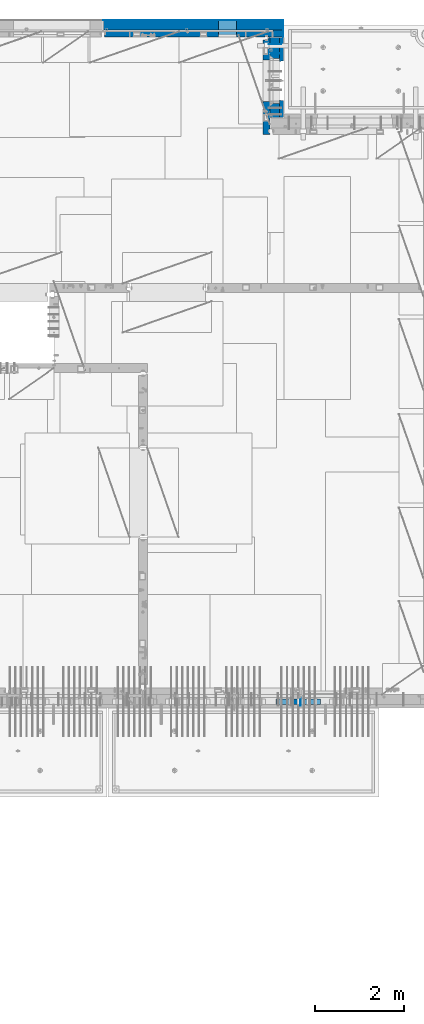
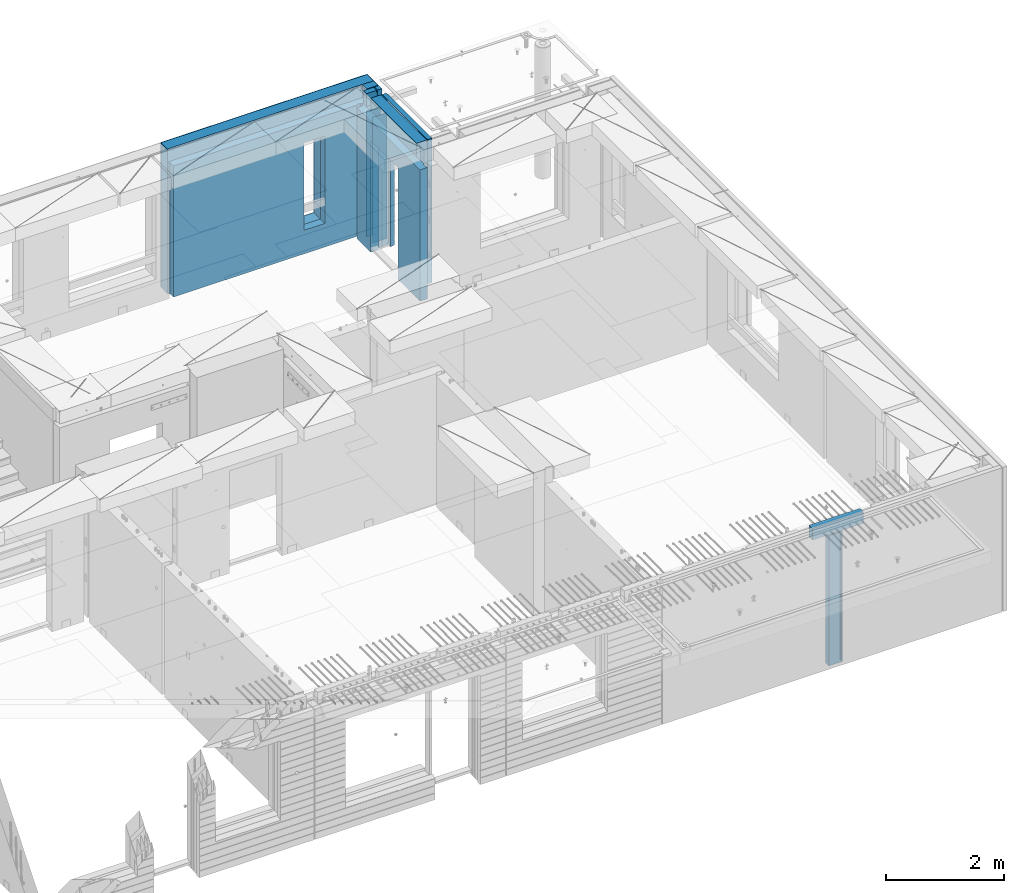
# One storey, part 229 of 334: 13 walls, 5 elements without a shape of their own.
"""IFC2X3 building model written with IfcOpenShell, lengths in millimetres."""

from ifc_helpers import new_model, si_unit, frame, origin_with_axes, place, context, subcontext, project, spatial, faceted_brep, material, type_object, element, aggregate, save


model = new_model("IFC2X3")

# Units and contexts
model_context = context("Model", 3, precision=1e-05, world=origin_with_axes())
body_context = subcontext(model_context, "Body", "Model", "MODEL_VIEW")
ifc_project = project(units=[si_unit("LENGTHUNIT", "METRE", prefix="MILLI"), si_unit("AREAUNIT", "SQUARE_METRE"), si_unit("VOLUMEUNIT", "CUBIC_METRE"), si_unit("MASSUNIT", "GRAM", prefix="KILO"), si_unit("TIMEUNIT", "SECOND"), si_unit("PLANEANGLEUNIT", "RADIAN"), si_unit("SOLIDANGLEUNIT", "STERADIAN"), si_unit("THERMODYNAMICTEMPERATUREUNIT", "DEGREE_CELSIUS"), si_unit("LUMINOUSINTENSITYUNIT", "LUMEN")], contexts=[model_context])

# Site, building, storey
site_placement = place(None, origin_with_axes())
site = spatial("IfcSite", under=ifc_project, at=site_placement, CompositionType="ELEMENT")
building_placement = place(site_placement, origin_with_axes())
building = spatial("IfcBuilding", under=site, at=building_placement, CompositionType="ELEMENT")
storey_placement = place(building_placement, origin_with_axes())
storey = spatial("IfcBuildingStorey", under=building, at=storey_placement, Name="3", CompositionType="ELEMENT", Elevation=0.0)

# Assembly, wall
assembly_1_placement = place(storey_placement, origin_with_axes())
assembly_1 = element("IfcElementAssembly", 1, at=assembly_1_placement, inside=storey, AssemblyPlace="NOTDEFINED", PredefinedType="REINFORCEMENT_UNIT")
ifc_material_1 = material(Name="Undefined")
wall_type_1 = type_object("IfcWallType", PredefinedType="NOTDEFINED")
wall_1_placement = place(assembly_1_placement, frame((32144.9998946285, 7780.0, 89115.0), z_axis=(0.0, 0.0, 1.0), x_axis=(0.0, -1.0, 0.0)))
wall_1 = element("IfcWall", 2, at=wall_1_placement, type_object=wall_type_1, material=ifc_material_1, Name="(PD)", context=body_context, shape_type="Brep", body=[
    faceted_brep([(0.0, 5.0, -1300.0), (0.0, 5.0, 1300.0), (180.0, 5.0, 1300.0), (180.0, 5.0, -1300.0), (0.0, -5.0, 1300.0), (180.0, -5.0, 1300.0), (0.0, -5.0, -1300.0), (180.0, -5.0, -1300.0)], [[[0, 1, 2, 3]], [[1, 4, 5, 2]], [[4, 6, 7, 5]], [[6, 0, 3, 7]], [[5, 7, 3, 2]], [[6, 4, 1, 0]]]),
])

# Assembly, walls
assembly_2_placement = place(storey_placement, origin_with_axes())
assembly_2 = element("IfcElementAssembly", 3, at=assembly_2_placement, inside=storey, AssemblyPlace="NOTDEFINED", PredefinedType="REINFORCEMENT_UNIT")
wall_2_placement = place(assembly_2_placement, frame((31429.9951872276, 22245.0, 89115.0), z_axis=(0.0, 0.0, 1.0), x_axis=(1.0, 0.0, 0.0)))
wall_2 = element("IfcWall", 4, at=wall_2_placement, type_object=wall_type_1, material=ifc_material_1, Name="(PD)", context=body_context, shape_type="Brep", body=[
    faceted_brep([(0.0, 5.0, -1300.0), (0.0, 5.0, 1300.0), (280.0, 5.0, 1300.0), (280.0, 5.0, -1300.0), (0.0, -5.0, 1300.0), (280.0, -5.0, 1300.0), (0.0, -5.0, -1300.0), (280.0, -5.0, -1300.0)], [[[0, 1, 2, 3]], [[1, 4, 5, 2]], [[4, 6, 7, 5]], [[6, 0, 3, 7]], [[5, 7, 3, 2]], [[6, 4, 1, 0]]]),
])
wall_3_placement = place(assembly_2_placement, frame((31429.9951872276, 22454.9997558594, 89115.0), z_axis=(0.0, 0.0, 1.0), x_axis=(1.0, 0.0, 0.0)))
wall_3 = element("IfcWall", 5, at=wall_3_placement, type_object=wall_type_1, material=ifc_material_1, Name="(PD)", context=body_context, shape_type="Brep", body=[
    faceted_brep([(0.0, 5.0, -1300.0), (0.0, 5.0, 1300.0), (280.0, 5.0, 1300.0), (280.0, 5.0, -1300.0), (0.0, -5.0, 1300.0), (280.0, -5.0, 1300.0), (0.0, -5.0, -1300.0), (280.0, -5.0, -1300.0)], [[[0, 1, 2, 3]], [[1, 4, 5, 2]], [[4, 6, 7, 5]], [[6, 0, 3, 7]], [[5, 7, 3, 2]], [[6, 4, 1, 0]]]),
])

# Assemblies, wall
assembly_3_placement = place(storey_placement, origin_with_axes())
assembly_3 = element("IfcElementAssembly", 6, at=assembly_3_placement, inside=storey, AssemblyPlace="NOTDEFINED", PredefinedType="REINFORCEMENT_UNIT")
assembly_4_placement = place(assembly_3_placement, origin_with_axes())
assembly_4 = element("IfcElementAssembly", 7, at=assembly_4_placement, Name="Steel Assembly", AssemblyPlace="NOTDEFINED", PredefinedType="NOTDEFINED")
aggregate(assembly_3, [assembly_4])
ifc_material_2 = material()
wall_type_2 = type_object("IfcWallType", PredefinedType="NOTDEFINED")
wall_4_placement = place(assembly_4_placement, frame((31599.9998568133, 7690.00021946163, 90590.0), z_axis=(0.0, 0.0, 1.0), x_axis=(1.0, 0.0, 0.0)))
wall_4 = element("IfcWall", 8, at=wall_4_placement, type_object=wall_type_2, material=ifc_material_2, context=body_context, shape_type="Brep", body=[
    faceted_brep([(0.0, 60.0, -120.0), (0.0, 60.0, 120.0), (1000.0, 60.0, 120.0), (1000.0, 60.0, -120.0), (0.0, -60.0, 120.0), (1000.0, -60.0, 120.0), (0.0, -60.0, -120.0), (1000.0, -60.0, -120.0)], [[[0, 1, 2, 3]], [[1, 4, 5, 2]], [[4, 6, 7, 5]], [[6, 0, 3, 7]], [[5, 7, 3, 2]], [[6, 4, 1, 0]]]),
])
aggregate(assembly_4, [wall_4])

# Assembly, wall
assembly_5_placement = place(storey_placement, origin_with_axes())
assembly_5 = element("IfcElementAssembly", 9, at=assembly_5_placement, inside=storey, AssemblyPlace="NOTDEFINED", PredefinedType="REINFORCEMENT_UNIT")
ifc_material_3 = material()
wall_type_3 = type_object("IfcWallType", PredefinedType="NOTDEFINED")
wall_5_placement = place(assembly_5_placement, frame((31645.0, 22620.0, 89247.5), z_axis=(0.0, 0.0, 1.0), x_axis=(0.0, 1.0, 0.0)))
wall_5 = element("IfcWall", 10, at=wall_5_placement, type_object=wall_type_3, material=ifc_material_3, context=body_context, shape_type="Brep", body=[
    faceted_brep([(0.0, 110.0, -1492.5), (0.0, 110.0, 1492.5), (150.0, 110.0, 1492.5), (150.0, 110.0, -1492.5), (0.0, -110.0, 1492.5), (150.0, -110.0, 1492.5), (0.0, -110.0, -1492.5), (150.0, -110.0, -1492.5)], [[[0, 1, 2, 3]], [[1, 4, 5, 2]], [[4, 6, 7, 5]], [[6, 0, 3, 7]], [[5, 7, 3, 2]], [[6, 4, 1, 0]]]),
])

# Wall
ifc_material_4 = material(Name="COS5gt")
wall_6_placement = place(assembly_2_placement, frame((31569.9951872276, 22605.0, 89247.5), z_axis=(0.0, 0.0, 1.0), x_axis=(0.0, -1.0, 0.0)))
wall_6 = element("IfcWall", 11, at=wall_6_placement, type_object=wall_type_3, material=ifc_material_4, context=body_context, shape_type="Brep", body=[
    faceted_brep([(0.0, 90.0, -1492.5), (0.0, 90.0, -1442.5), (465.000109818619, 90.0, -1442.5), (465.000109818619, 90.0, -1492.5), (0.0, -110.0, -1492.5), (465.000109818619, -110.0, -1492.5), (1800.0, -110.0, 1492.5), (1800.0, 90.0, 1492.5), (255.0, 90.0, 1492.5), (255.0, -110.0, 1492.5), (1800.0, 90.0, -1442.5), (1800.0, 90.0, -1492.5), (1475.00010981862, 90.0, -1492.5), (1475.00010981862, 90.0, -1442.5), (1800.0, 110.0, -1442.5), (1475.00010981862, 110.0, -1442.5), (1800.0, 110.0, 1442.5), (1800.0, 90.0, 1442.5), (1800.0, -110.0, -1492.5), (1475.00010981862, -110.0, -1492.5), (1475.00010981862, -110.000000000004, 857.5), (1475.00010981862, 110.0, 857.5), (465.000109818619, -110.000000000004, 857.5), (465.000109818619, 110.0, 857.5), (255.0, -110.0, 1222.5), (105.0, -110.0, 1222.5), (105.0, -110.0, 1492.5), (0.0, -110.0, 1492.5), (0.0, 90.0, 1492.5), (105.0, 90.0, 1492.5), (0.0, 110.0, 1442.5), (0.0, 90.0, 1442.5), (105.0, 90.0, 1442.5), (105.0, 110.0, 1442.5), (0.0, 110.0, -1442.5), (465.000109818619, 110.0, -1442.5), (105.0, 110.0, 1222.5), (255.0, 110.0, 1222.5), (255.0, 110.0, 1442.5), (255.0, 90.0, 1442.5)], [[[0, 1, 2, 3]], [[4, 0, 3, 5]], [[6, 7, 8, 9]], [[10, 11, 12, 13]], [[14, 10, 13, 15]], [[16, 17, 7, 6, 18, 11, 10, 14]], [[11, 18, 19, 12]], [[15, 13, 12, 19, 20, 21]], [[21, 20, 22, 23]], [[19, 18, 6, 9, 24, 25, 26, 27, 4, 5, 22, 20]], [[28, 27, 26, 29]], [[30, 31, 32, 33]], [[0, 4, 27, 28, 31, 30, 34, 1]], [[1, 34, 35, 2]], [[23, 22, 5, 3, 2, 35]], [[34, 30, 33, 36, 37, 38, 16, 14, 15, 21, 23, 35]], [[17, 16, 38, 39]], [[7, 17, 39, 8]], [[38, 37, 24, 9, 8, 39]], [[36, 25, 24, 37]], [[33, 32, 29, 26, 25, 36]], [[31, 28, 29, 32]]]),
])

wall_7_placement = place(assembly_5_placement, frame((27720.0, 22880.0, 89247.5), z_axis=(0.0, 0.0, 1.0), x_axis=(1.0, 0.0, 0.0)))
wall_7 = element("IfcWall", 12, at=wall_7_placement, type_object=wall_type_3, material=ifc_material_3, context=body_context, shape_type="Brep", body=[
    faceted_brep([(0.0, -110.0, -1492.5), (0.0, 110.0, -1492.5), (4035.0, 110.0, -1492.5), (4035.0, -110.0, -1492.5), (0.0, -110.0, 1492.5), (0.0, 110.0, 1492.5), (4035.0, -110.0, 1492.5), (4035.0, 110.0, 1492.5), (2584.99948280293, 110.0, -1002.5), (2994.99948280293, 110.0, -1002.5), (2994.99948280293, 110.0, 807.5), (2584.99948280293, 110.0, 807.5), (2584.99948280293, -110.0, -1002.5), (2584.99948280293, -110.0, 807.5), (2994.99948280293, -110.0, 807.5), (2994.99948280293, -110.0, -1002.5)], [[[0, 1, 2, 3]], [[0, 4, 5, 1]], [[5, 4, 6, 7]], [[1, 5, 7, 2], [8, 9, 10, 11]], [[6, 3, 2, 7]], [[4, 0, 3, 6], [12, 13, 14, 15]], [[10, 14, 13, 11]], [[9, 15, 14, 10]], [[8, 12, 15, 9]], [[11, 13, 12, 8]]]),
])

ifc_material_5 = material(Name="CONCRETE/C30/37")
wall_type_4 = type_object("IfcWallType", PredefinedType="NOTDEFINED")
wall_8_placement = place(assembly_2_placement, frame((31722.4951872276, 22605.0, 89247.5), z_axis=(0.0, 0.0, 1.0), x_axis=(0.0, -1.0, 0.0)))
wall_8 = element("IfcWall", 13, at=wall_8_placement, type_object=wall_type_4, material=ifc_material_5, context=body_context, shape_type="Brep", body=[
    faceted_brep([(0.0, 32.4999992507037, 744.999999999258), (0.0, 32.4999991127006, 755.00000040044), (526.17471776616, 32.4999991126897, 755.000000400425), (526.174717749924, 32.4999992507001, 744.999999999229), (0.0, 42.5, 742.999999944761), (524.998050995091, 42.4999995462422, 742.999999944761), (0.0, 42.5, 606.999999889245), (524.998050995091, 42.4999994639038, 606.999999889245), (3.63797880709171e-12, 32.4999991127006, 605.00000040044), (526.17471776616, 32.4999991126897, 605.000000400425), (3.63797880709171e-12, 32.4999992507037, 594.999999999258), (526.174717749924, 32.4999992507001, 594.999999999229), (0.0, 42.5, 592.999999944761), (524.998050995091, 42.4999995343132, 592.999999944761), (0.0, 42.5, 456.999999889245), (524.998050995091, 42.4999994639038, 456.999999889245), (0.0, 32.4999991127006, 455.00000040044), (526.17471776616, 32.4999991126897, 455.000000400425), (0.0, 32.4999992507037, 444.999999999258), (526.174717749924, 32.4999992507001, 444.999999999229), (0.0, 42.5, 442.999999944761), (524.998050995091, 42.4999995254038, 442.999999944761), (0.0, 42.5, 306.999999889245), (524.998050995091, 42.4999994639038, 306.999999889245), (-3.63797880709171e-12, 32.4999991127006, 305.00000040044), (526.17471776616, 32.4999991126897, 305.000000400425), (-3.63797880709171e-12, 32.4999992507037, 294.999999999258), (526.174717749924, 32.4999992507001, 294.999999999229), (0.0, 42.5, 292.999999944761), (524.998050995091, 42.499999518499, 292.999999944761), (0.0, 42.5, 156.999999889245), (524.998050995091, 42.4999994639038, 156.999999889245), (-3.63797880709171e-12, 32.4999991127006, 155.00000040044), (526.17471776616, 32.4999991126897, 155.000000400425), (-3.63797880709171e-12, 32.4999992507037, 144.999999999258), (526.174717749924, 32.4999992507001, 144.999999999229), (0.0, 42.5, 142.999999944761), (524.998050995091, 42.4999995129838, 142.999999944761), (0.0, 42.5, 6.99999988924537), (524.998050995091, 42.4999994639038, 6.99999988924537), (0.0, 32.4999991127006, 5.0000004004396), (526.17471776616, 32.4999991126897, 5.00000040042505), (0.0, 32.4999992507037, -5.00000000074215), (526.174717749924, 32.4999992507001, -5.00000000077125), (0.0, 42.5, -7.00000005523907), (524.998050995091, 42.49999950848, -7.00000005523907), (0.0, 42.5, -143.000000110755), (524.998050995091, 42.4999994639038, -143.000000110755), (3.63797880709171e-12, 32.4999991127006, -144.99999959956), (526.17471776616, 32.4999991126897, -144.999999599575), (3.63797880709171e-12, 32.4999992507037, -155.000000000742), (526.174717749924, 32.4999992507001, -155.000000000771), (0.0, 42.5, -157.000000055239), (524.998050995091, 42.4999995047365, -157.000000055239), (0.0, 42.5, -293.000000110755), (524.998050995091, 42.4999994639038, -293.000000110755), (0.0, 32.4999991127006, -294.99999959956), (526.17471776616, 32.4999991126897, -294.999999599575), (0.0, 32.4999992507037, -305.000000000742), (526.174717749924, 32.4999992507001, -305.000000000771), (0.0, 42.5, -307.000000055239), (524.998050995091, 42.4999995015714, -307.000000055239), (0.0, 42.5, -443.000000110755), (524.998050995091, 42.4999994639038, -443.000000110755), (0.0, 32.4999991127006, -444.99999959956), (526.17471776616, 32.4999991126897, -444.999999599575), (0.0, 32.4999992507037, -455.000000000742), (526.174717749924, 32.4999992507001, -455.000000000771), (0.0, 42.5, -457.000000055239), (524.998050995091, 42.4999994988648, -457.000000055239), (0.0, 42.5, -593.000000110755), (524.998050995091, 42.4999994639038, -593.000000110755), (3.63797880709171e-12, 32.4999991127006, -594.99999959956), (526.17471776616, 32.4999991126897, -594.999999599575), (3.63797880709171e-12, 32.4999992507037, -605.000000000742), (526.174717749924, 32.4999992507001, -605.000000000771), (0.0, 42.5, -607.000000055239), (524.998050995091, 42.4999994965183, -607.000000055239), (0.0, 42.5, -743.000000110755), (524.998050995091, 42.4999994639038, -743.000000110755), (0.0, 32.4999991127006, -744.99999959956), (526.17471776616, 32.4999991126897, -744.999999599575), (0.0, 32.4999992507037, -755.000000000742), (526.174717749924, 32.4999992507001, -755.000000000771), (0.0, 42.5, -757.000000055239), (524.998050995091, 42.4999994944665, -757.000000055239), (0.0, 42.5, -893.000000110755), (524.998050995091, 42.4999994639038, -893.000000110755), (0.0, 32.4999991127006, -894.99999959956), (526.17471776616, 32.4999991126897, -894.999999599575), (0.0, 32.4999992507037, -905.000000000742), (526.174717749924, 32.4999992507001, -905.000000000771), (0.0, 42.5, -907.000000055239), (524.998050995091, 42.4999994926584, -907.000000055239), (0.0, 42.5, -1043.00000011075), (524.998050995091, 42.4999994639038, -1043.00000011075), (0.0, 32.4999991127006, -1044.99999959956), (526.17471776616, 32.4999991126897, -1044.99999959957), (0.0, 32.4999992507037, -1055.00000000074), (526.174717749924, 32.4999992507001, -1055.00000000077), (0.0, 42.5, -1057.00000005524), (524.998050995091, 42.499999491054, -1057.00000005524), (0.0, 42.5, -1193.00000011075), (524.998050995091, 42.4999994639038, -1193.00000011075), (0.0, 32.4999991127006, -1194.99999959956), (526.17471776616, 32.4999991126897, -1194.99999959957), (0.0, 32.4999992507037, -1205.00000000074), (526.174717749924, 32.4999992507001, -1205.00000000077), (0.0, 42.5, -1207.00000005524), (524.998050995091, 42.499999489617, -1207.00000005524), (0.0, 42.5, -1343.00000011075), (524.998050995091, 42.4999994639038, -1343.00000011075), (0.0, 32.4999991127006, -1344.99999959956), (526.17471776616, 32.4999991126897, -1344.99999959957), (0.0, 32.4999992507037, -1355.00000000074), (526.174717749924, 32.4999992507001, -1355.00000000077), (0.0, 42.5, -1357.00000005524), (524.998050995091, 42.5, -1357.00000005524), (0.0, 42.5, -1492.5), (524.998050995091, 42.5, -1492.5), (0.0, 42.5, 1356.99999988925), (0.0, 42.5, 1492.5), (105.0, 42.5, 1492.5), (105.0, 42.499999287309, 1356.99999988925), (0.0, -42.5, 1492.5), (105.0, -42.5, 1492.5), (1800.0, 32.4999991126897, 755.000000400425), (1800.0, 32.4999992507001, 744.999999999229), (1413.82138424026, 32.4999992507001, 744.999999999229), (1413.82138422402, 32.4999991126897, 755.000000400425), (1800.0, 42.5, 742.999999944761), (1414.99805099509, 42.4999998629828, 742.999999944761), (1800.0, 42.5, 606.999999889245), (1414.99805099509, 42.4999998381209, 606.999999889245), (1800.0, 32.4999991126897, 605.000000400425), (1413.82138422402, 32.4999991126897, 605.000000400425), (1800.0, 32.4999992507001, 594.999999999229), (1413.82138424026, 32.4999992507001, 594.999999999229), (1800.0, 42.5, 592.999999944761), (1414.99805099509, 42.4999998593812, 592.999999944761), (1800.0, 42.5, 456.999999889245), (1414.99805099509, 42.4999998381209, 456.999999889245), (1800.0, 32.4999991126897, 455.000000400425), (1413.82138422402, 32.4999991126897, 455.000000400425), (1800.0, 32.4999992507001, 444.999999999229), (1413.82138424026, 32.4999992507001, 444.999999999229), (1800.0, 42.5, 442.999999944761), (1414.99805099509, 42.4999998566891, 442.999999944761), (1800.0, 42.5, 306.999999889245), (1414.99805099509, 42.4999998381209, 306.999999889245), (1800.0, 32.4999991126897, 305.000000400425), (1413.82138422402, 32.4999991126897, 305.000000400425), (1800.0, 32.4999992507001, 294.999999999229), (1413.82138424026, 32.4999992507001, 294.999999999229), (1800.0, 42.5, 292.999999944761), (1414.99805099509, 42.4999998546045, 292.999999944761), (1800.0, 42.5, 156.999999889245), (1414.99805099509, 42.4999998381209, 156.999999889245), (1800.0, 32.4999991126897, 155.000000400425), (1413.82138422402, 32.4999991126897, 155.000000400425), (1800.0, 32.4999992507001, 144.999999999229), (1413.82138424026, 32.4999992507001, 144.999999999229), (1800.0, 42.5, 142.999999944761), (1414.99805099509, 42.4999998529383, 142.999999944761), (1800.0, 42.5, 6.99999988924537), (1414.99805099509, 42.4999998381209, 6.99999988924537), (1800.0, 32.4999991126897, 5.00000040042505), (1413.82138422402, 32.4999991126897, 5.00000040042505), (1800.0, 32.4999992507001, -5.00000000077125), (1413.82138424026, 32.4999992507001, -5.00000000077125), (1800.0, 42.5, -7.00000005523907), (1414.99805099509, 42.4999998515814, -7.00000005523907), (1800.0, 42.5, -143.000000110755), (1414.99805099509, 42.4999998381209, -143.000000110755), (1800.0, 32.4999991126897, -144.999999599575), (1413.82138422402, 32.4999991126897, -144.999999599575), (1800.0, 32.4999992507001, -155.000000000771), (1413.82138424026, 32.4999992507001, -155.000000000771), (1800.0, 42.5, -157.000000055239), (1414.99805099509, 42.49999985045, -157.000000055239), (1800.0, 42.5, -293.000000110755), (1414.99805099509, 42.4999998381209, -293.000000110755), (1800.0, 32.4999991126897, -294.999999599575), (1413.82138422402, 32.4999991126897, -294.999999599575), (1800.0, 32.4999992507001, -305.000000000771), (1413.82138424026, 32.4999992507001, -305.000000000771), (1800.0, 42.5, -307.000000055239), (1414.99805099509, 42.4999998494932, -307.000000055239), (1800.0, 42.5, -443.000000110755), (1414.99805099509, 42.4999998381209, -443.000000110755), (1800.0, 32.4999991126897, -444.999999599575), (1413.82138422402, 32.4999991126897, -444.999999599575), (1800.0, 32.4999992507001, -455.000000000771), (1413.82138424026, 32.4999992507001, -455.000000000771), (1800.0, 42.5, -457.000000055239), (1414.99805099509, 42.4999998486746, -457.000000055239), (1800.0, 42.5, -593.000000110755), (1414.99805099509, 42.4999998381209, -593.000000110755), (1800.0, 32.4999991126897, -594.999999599575), (1413.82138422402, 32.4999991126897, -594.999999599575), (1800.0, 32.4999992507001, -605.000000000771), (1413.82138424026, 32.4999992507001, -605.000000000771), (1800.0, 42.5, -607.000000055239), (1414.99805099509, 42.4999998479689, -607.000000055239), (1800.0, 42.5, -743.000000110755), (1414.99805099509, 42.4999998381209, -743.000000110755), (1800.0, 32.4999991126897, -744.999999599575), (1413.82138422402, 32.4999991126897, -744.999999599575), (1800.0, 32.4999992507001, -755.000000000771), (1413.82138424026, 32.4999992507001, -755.000000000771), (1800.0, 42.5, -757.000000055239), (1414.99805099509, 42.4999998473468, -757.000000055239), (1800.0, 42.5, -893.000000110755), (1414.99805099509, 42.4999998381209, -893.000000110755), (1800.0, 32.4999991126897, -894.999999599575), (1413.82138422402, 32.4999991126897, -894.999999599575), (1800.0, 32.4999992507001, -905.000000000771), (1413.82138424026, 32.4999992507001, -905.000000000771), (1800.0, 42.5, -907.000000055239), (1414.99805099509, 42.4999998468011, -907.000000055239), (1800.0, 42.5, -1043.00000011075), (1414.99805099509, 42.4999998381209, -1043.00000011075), (1800.0, 32.4999991126897, -1044.99999959957), (1413.82138422402, 32.4999991126897, -1044.99999959957), (1800.0, 32.4999992507001, -1055.00000000077), (1413.82138424026, 32.4999992507001, -1055.00000000077), (1800.0, 42.5, -1057.00000005524), (1414.99805099509, 42.4999998463172, -1057.00000005524), (1800.0, 42.5, -1193.00000011075), (1414.99805099509, 42.4999998381209, -1193.00000011075), (1800.0, 32.4999991126897, -1194.99999959957), (1413.82138422402, 32.4999991126897, -1194.99999959957), (1800.0, 32.4999992507001, -1205.00000000077), (1413.82138424026, 32.4999992507001, -1205.00000000077), (1800.0, 42.5, -1207.00000005524), (1414.99805099509, 42.4999998458843, -1207.00000005524), (1800.0, 42.5, -1343.00000011075), (1414.99805099509, 42.4999998381209, -1343.00000011075), (1800.0, 32.4999991126897, -1344.99999959957), (1413.82138422402, 32.4999991126897, -1344.99999959957), (1800.0, 32.4999992507001, -1355.00000000077), (1413.82138424026, 32.4999992507001, -1355.00000000077), (1800.0, 42.5, -1357.00000005524), (1414.99805099509, 42.5, -1357.00000005524), (1800.0, 42.5, -1492.5), (1414.99805099509, 42.5, -1492.5), (1800.0, -42.5, -1492.5), (1404.99638432842, -42.5, -1492.5), (1414.99805099509, 42.4999998381209, 756.999999889245), (1404.99638432842, -42.5000000000036, 782.5), (1404.99638432842, -42.5000000000036, 787.502857142856), (1414.99805099509, 42.5, 782.5), (1800.0, 42.5, 756.999999889245), (0.0, 42.5, 892.999999944761), (0.0, 32.4999992507037, 894.999999999258), (1800.0, 32.4999992507001, 894.999999999229), (1800.0, 42.5, 892.999999944761), (0.0, 32.4999991127006, 905.00000040044), (1800.0, 32.4999991126897, 905.000000400425), (0.0, 42.5, 906.999999889245), (1800.0, 42.5, 906.999999889245), (0.0, 42.5, 1042.99999994476), (1800.0, 42.5, 1042.99999994476), (0.0, 32.4999992507037, 1044.99999999926), (1800.0, 32.4999992507001, 1044.99999999923), (0.0, 32.4999991127006, 1055.00000040044), (1800.0, 32.4999991126897, 1055.00000040043), (0.0, 42.5, 1056.99999988925), (1800.0, 42.5, 1056.99999988925), (0.0, 42.5, 1192.99999994476), (1800.0, 42.5, 1192.99999994476), (1800.0, -42.5, 1492.5), (1800.0, 42.5, 1492.5), (255.0, 42.5, 1492.5), (255.0, -42.5, 1492.5), (1800.0, 42.5, 1356.99999988925), (255.0, 42.499999350377, 1356.99999988925), (1800.0, 32.4999991126897, 1355.00000040043), (1800.0, 32.4999992507001, 1344.99999999923), (255.0, 32.4999992507001, 1344.99999999923), (255.0, 32.4999991126897, 1355.00000040043), (1800.0, 42.5, 1342.99999994476), (255.0, 42.4999996598308, 1342.99999994476), (105.0, 42.4999993874699, 1222.5), (105.0, -42.5, 1222.5), (255.0, -42.5, 1222.5), (255.0, 42.4999994355167, 1222.5), (1800.0, 32.4999992507001, 1194.99999999923), (1800.0, 32.4999991126897, 1205.00000040043), (1800.0, 42.5, 1206.99999988925), (0.0, 32.4999992507037, 1194.99999999926), (0.0, 32.4999991127006, 1205.00000040044), (0.0, 42.5, 1206.99999988925), (0.0, 42.5, 1342.99999994476), (105.0, 42.4999996268052, 1342.99999994476), (-3.63797880709171e-12, 32.4999992507037, 1344.99999999926), (105.0, 32.4999992507001, 1344.99999999923), (-3.63797880709171e-12, 32.4999991127006, 1355.00000040044), (105.0, 32.4999991126897, 1355.00000040043), (0.0, 42.5, 756.999999889245), (0.0, -42.5, -1492.5), (534.999717661754, -42.5, -1492.5), (534.999717661758, -42.5000000000036, 782.5), (534.999717661758, -42.5000000000036, 787.502857142856), (535.000109818619, 42.5, 782.5), (1405.00010981862, 42.5, 782.5), (524.998050995091, 42.5, 782.5), (524.998050995091, 42.4999994639038, 756.999999889245)], [[[0, 1, 2, 3]], [[4, 0, 3, 5]], [[6, 4, 5, 7]], [[8, 6, 7, 9]], [[10, 8, 9, 11]], [[12, 10, 11, 13]], [[14, 12, 13, 15]], [[16, 14, 15, 17]], [[18, 16, 17, 19]], [[20, 18, 19, 21]], [[22, 20, 21, 23]], [[24, 22, 23, 25]], [[26, 24, 25, 27]], [[28, 26, 27, 29]], [[30, 28, 29, 31]], [[32, 30, 31, 33]], [[34, 32, 33, 35]], [[36, 34, 35, 37]], [[38, 36, 37, 39]], [[40, 38, 39, 41]], [[42, 40, 41, 43]], [[44, 42, 43, 45]], [[46, 44, 45, 47]], [[48, 46, 47, 49]], [[50, 48, 49, 51]], [[52, 50, 51, 53]], [[54, 52, 53, 55]], [[56, 54, 55, 57]], [[58, 56, 57, 59]], [[60, 58, 59, 61]], [[62, 60, 61, 63]], [[64, 62, 63, 65]], [[66, 64, 65, 67]], [[68, 66, 67, 69]], [[70, 68, 69, 71]], [[72, 70, 71, 73]], [[74, 72, 73, 75]], [[76, 74, 75, 77]], [[78, 76, 77, 79]], [[80, 78, 79, 81]], [[82, 80, 81, 83]], [[84, 82, 83, 85]], [[86, 84, 85, 87]], [[88, 86, 87, 89]], [[90, 88, 89, 91]], [[92, 90, 91, 93]], [[94, 92, 93, 95]], [[96, 94, 95, 97]], [[98, 96, 97, 99]], [[100, 98, 99, 101]], [[102, 100, 101, 103]], [[104, 102, 103, 105]], [[106, 104, 105, 107]], [[108, 106, 107, 109]], [[110, 108, 109, 111]], [[112, 110, 111, 113]], [[114, 112, 113, 115]], [[116, 114, 115, 117]], [[118, 116, 117, 119]], [[120, 121, 122, 123]], [[121, 124, 125, 122]], [[126, 127, 128, 129]], [[127, 130, 131, 128]], [[130, 132, 133, 131]], [[132, 134, 135, 133]], [[134, 136, 137, 135]], [[136, 138, 139, 137]], [[138, 140, 141, 139]], [[140, 142, 143, 141]], [[142, 144, 145, 143]], [[144, 146, 147, 145]], [[146, 148, 149, 147]], [[148, 150, 151, 149]], [[150, 152, 153, 151]], [[152, 154, 155, 153]], [[154, 156, 157, 155]], [[156, 158, 159, 157]], [[158, 160, 161, 159]], [[160, 162, 163, 161]], [[162, 164, 165, 163]], [[164, 166, 167, 165]], [[166, 168, 169, 167]], [[168, 170, 171, 169]], [[170, 172, 173, 171]], [[172, 174, 175, 173]], [[174, 176, 177, 175]], [[176, 178, 179, 177]], [[178, 180, 181, 179]], [[180, 182, 183, 181]], [[182, 184, 185, 183]], [[184, 186, 187, 185]], [[186, 188, 189, 187]], [[188, 190, 191, 189]], [[190, 192, 193, 191]], [[192, 194, 195, 193]], [[194, 196, 197, 195]], [[196, 198, 199, 197]], [[198, 200, 201, 199]], [[200, 202, 203, 201]], [[202, 204, 205, 203]], [[204, 206, 207, 205]], [[206, 208, 209, 207]], [[208, 210, 211, 209]], [[210, 212, 213, 211]], [[212, 214, 215, 213]], [[214, 216, 217, 215]], [[216, 218, 219, 217]], [[218, 220, 221, 219]], [[220, 222, 223, 221]], [[222, 224, 225, 223]], [[224, 226, 227, 225]], [[226, 228, 229, 227]], [[228, 230, 231, 229]], [[230, 232, 233, 231]], [[232, 234, 235, 233]], [[234, 236, 237, 235]], [[236, 238, 239, 237]], [[238, 240, 241, 239]], [[240, 242, 243, 241]], [[242, 244, 245, 243]], [[244, 246, 247, 245]], [[248, 129, 128, 131, 133, 135, 137, 139, 141, 143, 145, 147, 149, 151, 153, 155, 157, 159, 161, 163, 165, 167, 169, 171, 173, 175, 177, 179, 181, 183, 185, 187, 189, 191, 193, 195, 197, 199, 201, 203, 205, 207, 209, 211, 213, 215, 217, 219, 221, 223, 225, 227, 229, 231, 233, 235, 237, 239, 241, 243, 245, 247, 249, 250, 251]], [[252, 126, 129, 248]], [[253, 254, 255, 256]], [[257, 258, 255, 254]], [[259, 260, 258, 257]], [[260, 259, 261, 262]], [[261, 263, 264, 262]], [[265, 266, 264, 263]], [[267, 268, 266, 265]], [[268, 267, 269, 270]], [[271, 272, 273, 274]], [[272, 275, 276, 273]], [[277, 278, 279, 280]], [[278, 281, 282, 279]], [[283, 284, 285, 286]], [[273, 276, 280, 279, 282, 286, 285, 274]], [[275, 277, 280, 276]], [[272, 271, 246, 244, 242, 240, 238, 236, 234, 232, 230, 228, 226, 224, 222, 220, 218, 216, 214, 212, 210, 208, 206, 204, 202, 200, 198, 196, 194, 192, 190, 188, 186, 184, 182, 180, 178, 176, 174, 172, 170, 168, 166, 164, 162, 160, 158, 156, 154, 152, 150, 148, 146, 144, 142, 140, 138, 136, 134, 132, 130, 127, 126, 252, 256, 255, 258, 260, 262, 264, 266, 268, 270, 287, 288, 289, 281, 278, 277, 275]], [[269, 290, 287, 270]], [[291, 288, 287, 290]], [[292, 289, 288, 291]], [[286, 282, 281, 289, 292, 293, 294, 283]], [[293, 295, 296, 294]], [[295, 297, 298, 296]], [[122, 125, 284, 283, 294, 296, 298, 123]], [[297, 120, 123, 298]], [[295, 293, 292, 291, 290, 269, 267, 265, 263, 261, 259, 257, 254, 253, 299, 1, 0, 4, 6, 8, 10, 12, 14, 16, 18, 20, 22, 24, 26, 28, 30, 32, 34, 36, 38, 40, 42, 44, 46, 48, 50, 52, 54, 56, 58, 60, 62, 64, 66, 68, 70, 72, 74, 76, 78, 80, 82, 84, 86, 88, 90, 92, 94, 96, 98, 100, 102, 104, 106, 108, 110, 112, 114, 116, 118, 300, 124, 121, 120, 297]], [[249, 247, 246, 271, 274, 285, 284, 125, 124, 300, 301, 302, 303, 250]], [[304, 305, 251, 250, 303, 306]], [[299, 253, 256, 252, 248, 251, 305, 304, 306, 307]], [[1, 299, 307, 2]], [[306, 303, 302, 301, 119, 117, 115, 113, 111, 109, 107, 105, 103, 101, 99, 97, 95, 93, 91, 89, 87, 85, 83, 81, 79, 77, 75, 73, 71, 69, 67, 65, 63, 61, 59, 57, 55, 53, 51, 49, 47, 45, 43, 41, 39, 37, 35, 33, 31, 29, 27, 25, 23, 21, 19, 17, 15, 13, 11, 9, 7, 5, 3, 2, 307]], [[300, 118, 119, 301]]]),
])

ifc_material_6 = material(Name="CONCRETE/C25/30")
wall_type_5 = type_object("IfcWallType", PredefinedType="NOTDEFINED")
wall_9_placement = place(assembly_2_placement, frame((31384.9951872276, 22620.0, 89112.5), z_axis=(0.0, 0.0, 1.0), x_axis=(0.0, -1.0, 0.0)))
wall_9 = element("IfcWall", 14, at=wall_9_placement, type_object=wall_type_5, material=ifc_material_6, context=body_context, shape_type="Brep", body=[
    faceted_brep([(2190.00481277244, -75.0, 1357.5), (2190.00481277244, -75.0, -1357.5), (2190.00481277244, 75.0, -1357.5), (2190.00481277244, 75.0, 1357.5), (2168.00481277244, 75.0, -1357.5), (2168.00481277244, 75.0, 1357.5), (2155.00481277244, 55.0, -1357.5), (2155.00481277244, 55.0, 1357.5), (2075.00481277244, 55.0, -1357.5), (2075.00481277244, 55.0, 1357.5), (2062.00481277244, 75.0, 1357.5), (2062.00481277244, 75.0, -1357.5), (15.0, 75.0, 1357.5), (15.0, 53.6666666666642, 1357.5), (65.0, 32.0, 1357.5), (65.0, -75.0, 1357.5), (15.0, 75.0, -1357.5), (15.0, 53.6666666666642, -1357.5), (65.0, 32.0, -1357.5), (65.0, -75.0, -1357.5), (1450.00010981862, -75.0, -1357.5), (520.000109818619, -75.0, -1357.5), (520.000109818619, -75.0, 952.5), (1450.00010981862, -75.0, 952.5), (1446.15395597246, 75.0, -1357.5), (1446.15395597247, 75.0, 948.653846153844), (523.846263664771, 75.0, 948.653846153844), (523.846263664771, 75.0, -1357.5)], [[[0, 1, 2, 3]], [[3, 2, 4, 5]], [[5, 4, 6, 7]], [[7, 6, 8, 9]], [[10, 9, 8, 11]], [[12, 13, 14, 15, 0, 3, 5, 7, 9, 10]], [[12, 16, 17, 13]], [[13, 17, 18, 14]], [[14, 18, 19, 15]], [[20, 1, 0, 15, 19, 21, 22, 23]], [[11, 8, 6, 4, 2, 1, 20, 24]], [[16, 12, 10, 11, 24, 25, 26, 27]], [[19, 18, 17, 16, 27, 21]], [[26, 22, 21, 27]], [[25, 23, 22, 26]], [[24, 20, 23, 25]]]),
])

aggregate(assembly_2, [wall_2, wall_3, wall_8, wall_6, wall_9])

wall_10_placement = place(assembly_5_placement, frame((27720.0, 22695.0, 89112.5), z_axis=(0.0, 0.0, 1.0), x_axis=(1.0, 0.0, 0.0)))
wall_10 = element("IfcWall", 15, at=wall_10_placement, type_object=wall_type_5, material=ifc_material_6, context=body_context, shape_type="Brep", body=[
    faceted_brep([(2584.99948280293, 75.0, 942.5), (2584.99948280293, -75.0, 942.5), (2584.99948280293, -75.0, -867.5), (2584.99948280293, 75.0, -867.5), (2994.99948280293, -75.0, -867.5), (2994.99948280293, 75.0, -867.5), (2994.99948280293, -75.0, 942.5), (2994.99948280293, 75.0, 942.5), (3815.0, -75.0, 1357.5), (3815.0, -75.0, -1357.5), (3815.0, 75.0, -1357.5), (3815.0, 75.0, 1357.5), (0.0, 75.0, -1357.5), (0.0, 75.0, 1357.5), (0.0, 45.0, -1357.5), (0.0, 45.0, 1357.5), (29.9999989126591, 32.0000004547946, -1357.5), (29.9999989126591, 32.0000004547946, 1357.5), (30.0000016637459, -75.0, -1357.5), (30.0000016637459, -75.0, 1357.5), (3624.99518722756, -75.0, 1357.5), (3637.99518722756, -55.0, 1357.5), (3691.99518722756, -55.0, 1357.5), (3704.99518722756, -75.0, 1357.5), (3704.99518722756, -75.0, -1357.5), (3637.99518722756, -55.0, -1357.5), (3624.99518722756, -75.0, -1357.5), (3691.99518722756, -55.0, -1357.5)], [[[0, 1, 2, 3]], [[3, 2, 4, 5]], [[5, 4, 6, 7]], [[7, 6, 1, 0]], [[8, 9, 10, 11]], [[12, 13, 11, 10], [3, 5, 7, 0]], [[13, 12, 14, 15]], [[15, 14, 16, 17]], [[17, 16, 18, 19]], [[8, 11, 13, 15, 17, 19, 20, 21, 22, 23]], [[9, 8, 23, 24]], [[25, 26, 18, 16, 14, 12, 10, 9, 24, 27]], [[23, 22, 27, 24]], [[21, 25, 27, 22]], [[20, 26, 25, 21]], [[19, 18, 26, 20], [2, 1, 6, 4]]]),
])

wall_type_6 = type_object("IfcWallType", PredefinedType="NOTDEFINED")
wall_11_placement = place(assembly_5_placement, frame((31760.0001313636, 22620.0, 89247.5), z_axis=(0.0, 0.0, 1.0), x_axis=(0.0, 1.0, 0.0)))
wall_11 = element("IfcWall", 16, at=wall_11_placement, type_object=wall_type_6, material=ifc_material_5, context=body_context, shape_type="Brep", body=[
    faceted_brep([(0.0, 5.0, -1492.5), (0.0, 5.0, 1492.5), (370.0, 5.0, 1492.5), (370.0, 5.0, -1492.5), (0.0, -5.0, 1492.5), (370.0, -5.0, 1492.5), (0.0, -5.0, -1492.5), (370.0, -5.0, -1492.5)], [[[0, 1, 2, 3]], [[1, 4, 5, 2]], [[4, 6, 7, 5]], [[6, 0, 3, 7]], [[5, 7, 3, 2]], [[6, 4, 1, 0]]]),
])

wall_12_placement = place(assembly_5_placement, frame((27720.0, 22995.0, 89247.5), z_axis=(0.0, 0.0, 1.0), x_axis=(1.0, 0.0, 0.0)))
wall_12 = element("IfcWall", 17, at=wall_12_placement, type_object=wall_type_6, material=ifc_material_5, context=body_context, shape_type="Brep", body=[
    faceted_brep([(0.0, -5.0, -1492.5), (0.0, 5.0, -1492.5), (4045.0, 5.0, -1492.5), (4045.0, -5.0, -1492.5), (0.0, -5.0, 1492.5), (0.0, 5.0, 1492.5), (4045.0, -5.0, 1492.5), (4045.0, 5.0, 1492.5), (2584.99948280293, 5.0, -1002.5), (2994.99948280293, 5.0, -1002.5), (2994.99948280293, 5.0, 807.5), (2584.99948280293, 5.0, 807.5), (2584.99948280293, -5.0, -1002.5), (2584.99948280293, -5.0, 807.5), (2994.99948280293, -5.0, 807.5), (2994.99948280293, -5.0, -1002.5)], [[[0, 1, 2, 3]], [[0, 4, 5, 1]], [[5, 4, 6, 7]], [[1, 5, 7, 2], [8, 9, 10, 11]], [[6, 3, 2, 7]], [[4, 0, 3, 6], [12, 13, 14, 15]], [[10, 14, 13, 11]], [[9, 15, 14, 10]], [[8, 12, 15, 9]], [[11, 13, 12, 8]]]),
])

aggregate(assembly_5, [wall_11, wall_5, wall_12, wall_7, wall_10])

ifc_material_7 = material(Name="SPU")
wall_type_7 = type_object("IfcWallType", PredefinedType="NOTDEFINED")
wall_13_placement = place(assembly_1_placement, frame((32195.0000381475, 7690.0, 89102.5), z_axis=(0.0, 0.0, 1.0), x_axis=(-1.0, 3.00000001838171e-08, 0.0)))
wall_13 = element("IfcWall", 18, at=wall_13_placement, type_object=wall_type_7, material=ifc_material_7, context=body_context, shape_type="Brep", body=[
    faceted_brep([(0.0, 60.0, -1347.5), (0.0, 60.0, 1347.5), (270.001908754726, 60.0, 1347.5), (270.001908754726, 60.0, -1347.5), (0.0, -60.0, 1347.5), (270.001908754726, -60.0, 1347.5), (0.0, -60.0, -1347.5), (270.001908754726, -60.0, -1347.5)], [[[0, 1, 2, 3]], [[1, 4, 5, 2]], [[4, 6, 7, 5]], [[6, 0, 3, 7]], [[5, 7, 3, 2]], [[6, 4, 1, 0]]]),
])

aggregate(assembly_1, [wall_1, wall_13])

save(model, "model.ifc")
